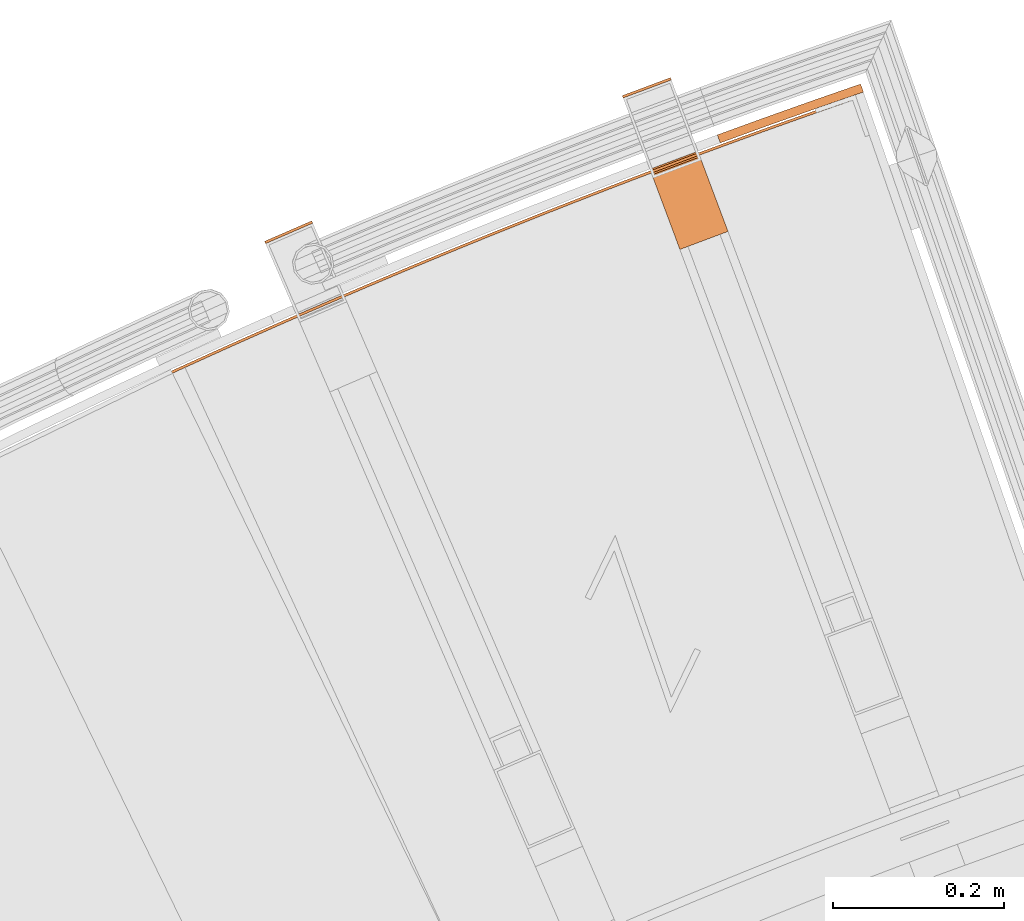
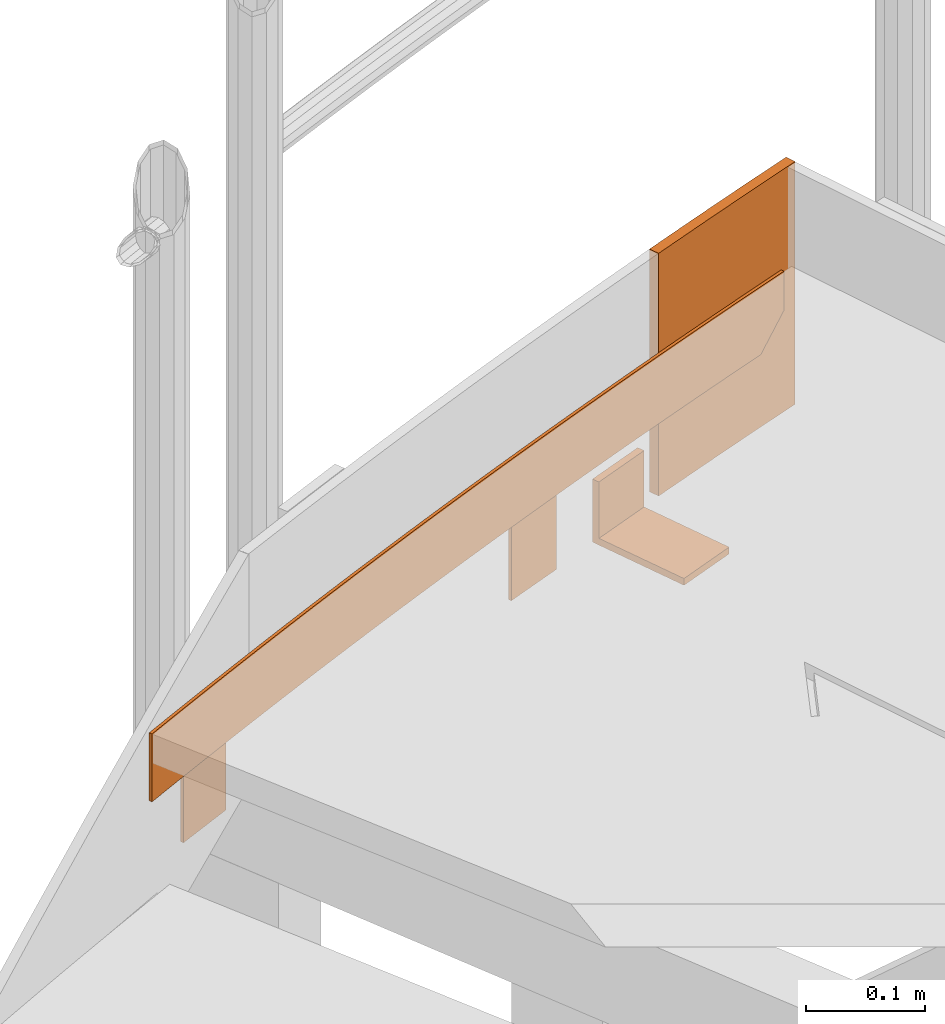
# One storey, part 98 of 126: 5 proxies.
"""IFC2X3 building model written with IfcOpenShell, lengths in millimetres."""

import ifcopenshell
import ifcopenshell.guid

model = None  # the IFC model being written
_history = None  # IfcOwnerHistory: only IFC2X3 demands one
_inside = {}  # id of a spatial element -> (the spatial element, [elements in it])
_under = {}  # id of a project, library or spatial element -> (it, [spatial elements below it])
_declared = {}  # id of a project -> (the project, [libraries it declares])
_typed = {}  # id of a type object -> (the type object, [elements of that type])
_made_of = {}  # id of a material, layer set ... -> (it, [elements and type objects made of it])


def new_model(schema):
    """Start an empty IFC model of exactly this schema.

    Asked for "IFC4X3", IfcOpenShell would pick the latest addendum, in which some entities
    have other attributes; the version numbers below select the first issue.
    IFC2X3 requires an IfcOwnerHistory on every rooted entity: one is made here for all.
    """
    global model, _history
    if schema == "IFC4X3":
        model = ifcopenshell.file(schema_version=(4, 3, 0, 0))
    else:
        model = ifcopenshell.file(schema=schema)
    _inside.clear()
    _under.clear()
    _declared.clear()
    _typed.clear()
    _made_of.clear()
    _history = None
    if model.schema == "IFC2X3":
        org = make("IfcOrganization", Name="unknown")
        user = make(
            "IfcPersonAndOrganization",
            ThePerson=make("IfcPerson", FamilyName="unknown"),
            TheOrganization=org,
        )
        app = make(
            "IfcApplication",
            ApplicationDeveloper=org,
            Version="unknown",
            ApplicationFullName="unknown",
            ApplicationIdentifier="unknown",
        )
        _history = make(
            "IfcOwnerHistory",
            OwningUser=user,
            OwningApplication=app,
            ChangeAction="ADDED",
            CreationDate=0,
        )
    return model


def make(cls, **values):
    """One entity of the class cls with the attributes given. An attribute that is None is left unset."""
    return model.create_entity(
        cls, **{name: value for name, value in values.items() if value is not None}
    )


def rooted(cls, **values):
    """An entity with a GlobalId (a new one), such as an element, a storey or a relation."""
    return make(cls, GlobalId=ifcopenshell.guid.new(), OwnerHistory=_history, **values)


def si_unit(unit_type, name, prefix=None):
    """IfcSIUnit, for example si_unit("LENGTHUNIT", "METRE", prefix="MILLI")."""
    return make("IfcSIUnit", UnitType=unit_type, Prefix=prefix, Name=name)


def assignment(units):
    """IfcUnitAssignment: the units of a project."""
    return None if units is None else make("IfcUnitAssignment", Units=units)


def point(xyz):
    """IfcCartesianPoint."""
    return None if xyz is None else make("IfcCartesianPoint", Coordinates=xyz)


def direction(xyz):
    """IfcDirection."""
    return None if xyz is None else make("IfcDirection", DirectionRatios=xyz)


def frame(location, z_axis=None, x_axis=None):
    """IfcAxis2Placement3D, a coordinate frame: its origin and axes. An axis left out is left unset."""
    return make(
        "IfcAxis2Placement3D",
        Location=point(location),
        Axis=direction(z_axis),
        RefDirection=direction(x_axis),
    )


def origin():
    """The frame at (0, 0, 0) with its axes left unset."""
    return frame((0.0, 0.0, 0.0))


def origin_with_axes():
    """The frame at (0, 0, 0) with the z axis (0, 0, 1) and the x axis (1, 0, 0) written out."""
    return frame((0.0, 0.0, 0.0), z_axis=(0.0, 0.0, 1.0), x_axis=(1.0, 0.0, 0.0))


def place(relative_to, where):
    """IfcLocalPlacement: puts the frame where relative to a parent placement (None: the world)."""
    return make(
        "IfcLocalPlacement", PlacementRelTo=relative_to, RelativePlacement=where
    )


def context(
    kind, dimensions, precision=None, world=None, true_north=None, identifier=None
):
    """IfcGeometricRepresentationContext, for example the 3D "Model" context."""
    return make(
        "IfcGeometricRepresentationContext",
        ContextIdentifier=identifier,
        ContextType=kind,
        CoordinateSpaceDimension=dimensions,
        Precision=precision,
        WorldCoordinateSystem=world,
        TrueNorth=true_north,
    )


def project(units=None, contexts=None):
    """IfcProject with its units and contexts."""
    return rooted(
        "IfcProject",
        Name="project",
        RepresentationContexts=contexts,
        UnitsInContext=assignment(units),
    )


def spatial(cls, under=None, at=None, **own):
    """A site, building, storey or space (cls), placed at a placement, below another one or the project."""
    s = rooted(cls, ObjectPlacement=at, **own)
    if under is not None:
        _under.setdefault(under.id(), (under, []))[1].append(s)
    return s


def faces_of(points, faces, orient=None, outer=None):
    """IfcFace entities. A face is a list of loops; a loop is a list of indices into points, from 0.

    orient and outer hold one flag for each loop. By default every Orientation is true, the
    first loop of a face is its IfcFaceOuterBound and the others are IfcFaceBound.
    """
    made = []
    for i, loops in enumerate(faces):
        bounds = []
        for j, loop in enumerate(loops):
            is_outer = j == 0 if outer is None else outer[i][j]
            bounds.append(
                make(
                    "IfcFaceOuterBound" if is_outer else "IfcFaceBound",
                    Bound=make("IfcPolyLoop", Polygon=[points[k] for k in loop]),
                    Orientation=True if orient is None else orient[i][j],
                )
            )
        made.append(make("IfcFace", Bounds=bounds))
    return made


def faceted_brep(points, faces, orient=None, outer=None, voids=None):
    """IfcFacetedBrep: a solid bounded by flat faces; with voids (closed shells), ...WithVoids."""
    shared = [point(p) for p in points]
    hull = make("IfcClosedShell", CfsFaces=faces_of(shared, faces, orient, outer))
    if voids is None:
        return make("IfcFacetedBrep", Outer=hull)
    return make(
        "IfcFacetedBrepWithVoids",
        Outer=hull,
        Voids=[
            make(cls, CfsFaces=faces_of(shared, fs, o, b)) for cls, fs, o, b in voids
        ],
    )


def shape(context_of_items, identifier, shape_type, items):
    """IfcShapeRepresentation: the items that make up one representation, for example the "Body"."""
    return make(
        "IfcShapeRepresentation",
        ContextOfItems=context_of_items,
        RepresentationIdentifier=identifier,
        RepresentationType=shape_type,
        Items=items,
    )


def material(Name=None, Category=None):
    """IfcMaterial."""
    return make("IfcMaterial", Name=Name, Category=Category)


def made_of(thing, what):
    """Note that an element or type object is made of a material, layer set ...; save() writes the relation."""
    if what is not None:
        _made_of.setdefault(what.id(), (what, []))[1].append(thing)
    return thing


def element(
    cls,
    number,
    at=None,
    inside=None,
    cuts=None,
    type_object=None,
    material=None,
    context=None,
    identifier="Body",
    shape_type=None,
    held_by="IfcProductDefinitionShape",
    body=None,
    shapes=None,
    **own,
):
    """One element of the class cls, such as IfcWall. Its Tag is "e" and its number.

    at: its placement. inside: the storey or other place that contains it. cuts: it is an
    opening in that element (IfcRelVoidsElement). A single representation is given by context,
    identifier, shape_type and body (its items); several are given by shapes. held_by: the class
    of the entity that holds the representations. save() writes the other relations.
    """
    e = rooted(cls, Tag="e%d" % number, ObjectPlacement=at, **own)
    if body is not None:
        shapes = [shape(context, identifier, shape_type, body)]
    if shapes is not None:
        e.Representation = make(held_by, Representations=shapes)
    if inside is not None:
        _inside.setdefault(inside.id(), (inside, []))[1].append(e)
    if cuts is not None:
        rooted(
            "IfcRelVoidsElement", RelatingBuildingElement=cuts, RelatedOpeningElement=e
        )
    if type_object is not None:
        _typed.setdefault(type_object.id(), (type_object, []))[1].append(e)
    return made_of(e, material)


def aggregate(whole, parts):
    """IfcRelAggregates: a whole, such as a stair, and the parts it consists of."""
    return rooted("IfcRelAggregates", RelatingObject=whole, RelatedObjects=parts)


def save(model, path):
    """Write the relations noted so far, then the file.

    IfcRelAggregates (storeys below a building ...), IfcRelContainedInSpatialStructure (elements
    in a storey), IfcRelDefinesByType, IfcRelAssociatesMaterial and IfcRelDeclares: one each for
    every whole, place, type object, material and project.
    """
    for whole, parts in _under.values():
        aggregate(whole, parts)
    for where, things in _inside.values():
        rooted(
            "IfcRelContainedInSpatialStructure",
            RelatedElements=things,
            RelatingStructure=where,
        )
    for kind, things in _typed.values():
        rooted("IfcRelDefinesByType", RelatedObjects=things, RelatingType=kind)
    for what, things in _made_of.values():
        rooted("IfcRelAssociatesMaterial", RelatedObjects=things, RelatingMaterial=what)
    for by, libraries in _declared.values():
        rooted("IfcRelDeclares", RelatingContext=by, RelatedDefinitions=libraries)
    model.write(path)


model = new_model("IFC2X3")

# Units and contexts
context_of_model_1 = context(None, 3, precision=0.1, world=origin())
context_of_model_2 = context(None, 3, precision=0.1, world=origin())
ifc_project = project(units=[si_unit("LENGTHUNIT", "METRE", prefix="MILLI"), si_unit("AREAUNIT", "SQUARE_METRE", prefix="CENTI"), si_unit("VOLUMEUNIT", "CUBIC_METRE", prefix="CENTI"), si_unit("MASSUNIT", "GRAM", prefix="KILO")], contexts=[context_of_model_1, context_of_model_2])

# Site, building, storey
site_placement = place(None, origin_with_axes())
site = spatial("IfcSite", under=ifc_project, at=site_placement, CompositionType="ELEMENT")
building_placement = place(site_placement, origin_with_axes())
building = spatial("IfcBuilding", under=site, at=building_placement, CompositionType="ELEMENT")
storey_placement = place(building_placement, origin_with_axes())
storey = spatial("IfcBuildingStorey", under=building, at=storey_placement, CompositionType="ELEMENT")

# Proxies
ifc_material = material(Name="S235JRG2")
proxy_1_placement = place(storey_placement, origin_with_axes())
element("IfcBuildingElementProxy", 1, at=proxy_1_placement, inside=storey, material=ifc_material, context=context_of_model_2, shape_type="Brep", body=[
    faceted_brep([(4491.5336, 16193.806, 10835.15), (4492.7258, 16191.053, 10835.15), (4437.6668, 16167.21, 10835.15), (4436.4746, 16169.963, 10835.15), (4491.5336, 16193.806, 10935.15), (4436.4746, 16169.963, 10935.15), (4437.6668, 16167.21, 10935.15), (4492.7258, 16191.053, 10935.15)], [[[0, 1, 2, 3]], [[4, 5, 6, 7]], [[0, 4, 7, 1]], [[1, 7, 6, 2]], [[2, 6, 5, 3]], [[3, 5, 4, 0]]]),
])
proxy_2_placement = place(storey_placement, origin_with_axes())
element("IfcBuildingElementProxy", 2, at=proxy_2_placement, inside=storey, material=ifc_material, context=context_of_model_2, shape_type="Brep", body=[
    faceted_brep([(4910.3289, 16361.076, 10835.15), (4911.3803, 16358.266, 10835.15), (4855.1855, 16337.239, 10835.15), (4854.1341, 16340.049, 10835.15), (4910.3289, 16361.076, 10935.15), (4854.1341, 16340.049, 10935.15), (4855.1855, 16337.239, 10935.15), (4911.3803, 16358.266, 10935.15)], [[[0, 1, 2, 3]], [[4, 5, 6, 7]], [[0, 4, 7, 1]], [[1, 7, 6, 2]], [[2, 6, 5, 3]], [[3, 5, 4, 0]]]),
])
proxy_3_placement = place(storey_placement, origin_with_axes())
element("IfcBuildingElementProxy", 3, at=proxy_3_placement, inside=storey, material=ifc_material, context=context_of_model_2, shape_type="Brep", body=[
    faceted_brep([(4886.3098, 16254.06, 11000.15), (4942.5046, 16275.087, 11000.15), (4942.5046, 16275.087, 10935.15), (4886.3098, 16254.06, 10935.15), (4888.763, 16247.504, 11000.15), (4944.9578, 16268.531, 11000.15), (4888.763, 16247.504, 10942.15), (4944.9578, 16268.531, 10942.15), (4921.355, 16160.402, 10942.15), (4977.5499, 16181.429, 10942.15), (4921.355, 16160.402, 10935.15), (4977.5499, 16181.429, 10935.15)], [[[0, 1, 2, 3]], [[0, 4, 5, 1]], [[4, 6, 7, 5]], [[6, 8, 9, 7]], [[8, 10, 11, 9]], [[3, 2, 11, 10]], [[3, 10, 8, 6, 4, 0]], [[1, 5, 7, 9, 11, 2]]]),
])
proxy_4_placement = place(storey_placement, origin_with_axes())
element("IfcBuildingElementProxy", 4, at=proxy_4_placement, inside=storey, material=ifc_material, context=context_of_model_2, shape_type="Brep", body=[
    faceted_brep([(4315.0715, 16012.741, 11015.15), (4316.327, 16010.016, 11015.15), (4316.327, 16010.016, 11085.15), (4315.0715, 16012.741, 11085.15), (4322.9299, 16016.362, 11015.15), (4324.1827, 16013.636, 11015.15), (4324.1827, 16013.636, 11085.15), (4322.9299, 16016.362, 11085.15), (4338.6607, 16023.573, 11015.15), (4339.9082, 16020.845, 11015.15), (4339.9082, 16020.845, 11085.15), (4338.6607, 16023.573, 11085.15), (4354.4057, 16030.754, 11015.15), (4355.6478, 16028.023, 11015.15), (4355.6478, 16028.023, 11085.15), (4354.4057, 16030.754, 11085.15), (4370.1648, 16037.903, 11015.15), (4371.4015, 16035.17, 11015.15), (4371.4015, 16035.17, 11085.15), (4370.1648, 16037.903, 11085.15), (4385.9378, 16045.022, 11015.15), (4387.1692, 16042.286, 11015.15), (4387.1692, 16042.286, 11085.15), (4385.9378, 16045.022, 11085.15), (4401.7248, 16052.109, 11015.15), (4402.9508, 16049.371, 11015.15), (4402.9508, 16049.371, 11085.15), (4401.7248, 16052.109, 11085.15), (4417.5257, 16059.166, 11015.15), (4418.7463, 16056.425, 11015.15), (4418.7463, 16056.425, 11085.15), (4417.5257, 16059.166, 11085.15), (4433.3404, 16066.192, 11015.15), (4434.5556, 16063.449, 11015.15), (4434.5556, 16063.449, 11085.15), (4433.3404, 16066.192, 11085.15), (4449.1688, 16073.186, 11015.15), (4450.3787, 16070.441, 11015.15), (4450.3787, 16070.441, 11085.15), (4449.1688, 16073.186, 11085.15), (4465.011, 16080.149, 11015.15), (4466.2154, 16077.402, 11015.15), (4466.2154, 16077.402, 11085.15), (4465.011, 16080.149, 11085.15), (4480.8667, 16087.082, 11015.15), (4482.0658, 16084.332, 11015.15), (4482.0658, 16084.332, 11085.15), (4480.8667, 16087.082, 11085.15), (4496.7361, 16093.983, 11015.15), (4497.9298, 16091.231, 11015.15), (4497.9298, 16091.231, 11085.15), (4496.7361, 16093.983, 11085.15), (4512.619, 16100.853, 11015.15), (4513.8072, 16098.098, 11015.15), (4513.8072, 16098.098, 11085.15), (4512.619, 16100.853, 11085.15), (4528.5153, 16107.692, 11015.15), (4529.6982, 16104.935, 11015.15), (4529.6982, 16104.935, 11085.15), (4528.5153, 16107.692, 11085.15), (4544.425, 16114.499, 11015.15), (4545.6025, 16111.74, 11015.15), (4545.6025, 16111.74, 11085.15), (4544.425, 16114.499, 11085.15), (4560.3481, 16121.276, 11015.15), (4561.5201, 16118.514, 11015.15), (4561.5201, 16118.514, 11085.15), (4560.3481, 16121.276, 11085.15), (4576.2844, 16128.021, 11015.15), (4577.451, 16125.257, 11015.15), (4577.451, 16125.257, 11085.15), (4576.2844, 16128.021, 11085.15), (4592.2339, 16134.735, 11015.15), (4593.3951, 16131.968, 11015.15), (4593.3951, 16131.968, 11085.15), (4592.2339, 16134.735, 11085.15), (4608.1966, 16141.417, 11015.15), (4609.3523, 16138.649, 11015.15), (4609.3523, 16138.649, 11085.15), (4608.1966, 16141.417, 11085.15), (4624.1723, 16148.068, 11015.15), (4625.3226, 16145.298, 11015.15), (4625.3226, 16145.298, 11085.15), (4624.1723, 16148.068, 11085.15), (4640.1611, 16154.688, 11015.15), (4641.306, 16151.915, 11015.15), (4641.306, 16151.915, 11085.15), (4640.1611, 16154.688, 11085.15), (4656.1628, 16161.276, 11015.15), (4657.3023, 16158.501, 11015.15), (4657.3023, 16158.501, 11085.15), (4656.1628, 16161.276, 11085.15), (4672.1775, 16167.833, 11015.15), (4673.3115, 16165.056, 11015.15), (4673.3115, 16165.056, 11085.15), (4672.1775, 16167.833, 11085.15), (4688.205, 16174.359, 11015.15), (4689.3335, 16171.579, 11015.15), (4689.3335, 16171.579, 11085.15), (4688.205, 16174.359, 11085.15), (4704.2452, 16180.853, 11015.15), (4705.3683, 16178.071, 11015.15), (4705.3683, 16178.071, 11085.15), (4704.2452, 16180.853, 11085.15), (4720.2982, 16187.316, 11015.15), (4721.4158, 16184.531, 11015.15), (4721.4158, 16184.531, 11085.15), (4720.2982, 16187.316, 11085.15), (4736.3638, 16193.747, 11015.15), (4737.476, 16190.96, 11015.15), (4737.476, 16190.96, 11085.15), (4736.3638, 16193.747, 11085.15), (4752.442, 16200.146, 11015.15), (4753.5487, 16197.358, 11015.15), (4753.5487, 16197.358, 11085.15), (4752.442, 16200.146, 11085.15), (4768.5328, 16206.514, 11015.15), (4769.634, 16203.724, 11015.15), (4769.634, 16203.724, 11085.15), (4768.5328, 16206.514, 11085.15), (4784.636, 16212.85, 11015.15), (4785.7317, 16210.058, 11015.15), (4785.7317, 16210.058, 11085.15), (4784.636, 16212.85, 11085.15), (4800.7516, 16219.155, 11015.15), (4801.8418, 16216.36, 11015.15), (4801.8418, 16216.36, 11085.15), (4800.7516, 16219.155, 11085.15), (4816.8795, 16225.428, 11015.15), (4817.9643, 16222.631, 11015.15), (4817.9643, 16222.631, 11085.15), (4816.8795, 16225.428, 11085.15), (4833.0198, 16231.67, 11015.15), (4834.0991, 16228.871, 11015.15), (4834.0991, 16228.871, 11085.15), (4833.0198, 16231.67, 11085.15), (4849.1722, 16237.879, 11015.15), (4850.246, 16235.078, 11015.15), (4850.246, 16235.078, 11085.15), (4849.1722, 16237.879, 11085.15), (4865.3369, 16244.057, 11015.15), (4866.4051, 16241.254, 11015.15), (4866.4051, 16241.254, 11085.15), (4865.3369, 16244.057, 11085.15), (4881.5136, 16250.204, 11015.15), (4882.5763, 16247.398, 11015.15), (4882.5763, 16247.398, 11085.15), (4881.5136, 16250.204, 11085.15), (4897.7023, 16256.318, 11015.15), (4898.7596, 16253.511, 11015.15), (4898.7596, 16253.511, 11085.15), (4897.7023, 16256.318, 11085.15), (4913.903, 16262.401, 11015.15), (4914.9548, 16259.591, 11015.15), (4914.9548, 16259.591, 11085.15), (4913.903, 16262.401, 11085.15), (4930.1156, 16268.452, 11015.15), (4931.1619, 16265.64, 11015.15), (4931.1619, 16265.64, 11085.15), (4930.1156, 16268.452, 11085.15), (4946.3401, 16274.471, 11015.15), (4947.3808, 16271.657, 11015.15), (4947.3808, 16271.657, 11085.15), (4946.3401, 16274.471, 11085.15), (4962.5764, 16280.458, 11015.15), (4963.6115, 16277.642, 11015.15), (4963.6115, 16277.642, 11085.15), (4962.5764, 16280.458, 11085.15), (4978.8243, 16286.414, 11015.15), (4979.854, 16283.596, 11015.15), (4979.854, 16283.596, 11085.15), (4978.8243, 16286.414, 11085.15), (4995.0839, 16292.337, 11015.15), (4996.1081, 16289.517, 11015.15), (4996.1081, 16289.517, 11085.15), (4995.0839, 16292.337, 11085.15), (5011.3552, 16298.228, 11015.15), (5012.3738, 16295.407, 11015.15), (5012.3738, 16295.407, 11085.15), (5011.3552, 16298.228, 11085.15), (5027.6379, 16304.088, 11015.15), (5028.651, 16301.264, 11015.15), (5028.651, 16301.264, 11085.15), (5027.6379, 16304.088, 11085.15), (5043.9321, 16309.916, 11015.15), (5044.9396, 16307.09, 11015.15), (5044.9396, 16307.09, 11085.15), (5043.9321, 16309.916, 11085.15), (5060.2378, 16315.711, 11015.15), (5061.2397, 16312.884, 11015.15), (5061.2397, 16312.884, 11085.15), (5060.2378, 16315.711, 11085.15), (5076.5547, 16321.475, 11015.15), (5077.5511, 16318.645, 11015.15), (5077.5511, 16318.645, 11085.15), (5076.5547, 16321.475, 11085.15), (5088.9364, 16325.821, 11015.15), (5090.1975, 16323.084, 11015.15), (5093.8738, 16324.375, 11019.029), (5093.8738, 16324.375, 11085.15), (5092.883, 16327.207, 11085.15), (5092.883, 16327.207, 11019.314), (5110.2077, 16330.072, 11036.248), (5110.2077, 16330.072, 11085.15), (5109.2224, 16332.906, 11085.15), (5109.2224, 16332.906, 11036.539), (5118.3803, 16332.905, 11044.856), (5118.3803, 16332.905, 11085.15), (5117.3978, 16335.74, 11085.15), (5117.3978, 16335.74, 11045.15)], [[[0, 1, 2, 3]], [[0, 4, 5, 1]], [[1, 5, 6, 2]], [[2, 6, 7, 3]], [[3, 7, 4, 0]], [[4, 8, 9, 5]], [[5, 9, 10, 6]], [[6, 10, 11, 7]], [[7, 11, 8, 4]], [[8, 12, 13, 9]], [[9, 13, 14, 10]], [[10, 14, 15, 11]], [[11, 15, 12, 8]], [[12, 16, 17, 13]], [[13, 17, 18, 14]], [[14, 18, 19, 15]], [[15, 19, 16, 12]], [[16, 20, 21, 17]], [[17, 21, 22, 18]], [[18, 22, 23, 19]], [[19, 23, 20, 16]], [[20, 24, 25, 21]], [[21, 25, 26, 22]], [[22, 26, 27, 23]], [[23, 27, 24, 20]], [[24, 28, 29, 25]], [[25, 29, 30, 26]], [[26, 30, 31, 27]], [[27, 31, 28, 24]], [[28, 32, 33, 29]], [[29, 33, 34, 30]], [[30, 34, 35, 31]], [[31, 35, 32, 28]], [[32, 36, 37, 33]], [[33, 37, 38, 34]], [[34, 38, 39, 35]], [[35, 39, 36, 32]], [[36, 40, 41, 37]], [[37, 41, 42, 38]], [[38, 42, 43, 39]], [[39, 43, 40, 36]], [[40, 44, 45, 41]], [[41, 45, 46, 42]], [[42, 46, 47, 43]], [[43, 47, 44, 40]], [[44, 48, 49, 45]], [[45, 49, 50, 46]], [[46, 50, 51, 47]], [[47, 51, 48, 44]], [[48, 52, 53, 49]], [[49, 53, 54, 50]], [[50, 54, 55, 51]], [[51, 55, 52, 48]], [[52, 56, 57, 53]], [[53, 57, 58, 54]], [[54, 58, 59, 55]], [[55, 59, 56, 52]], [[56, 60, 61, 57]], [[57, 61, 62, 58]], [[58, 62, 63, 59]], [[59, 63, 60, 56]], [[60, 64, 65, 61]], [[61, 65, 66, 62]], [[62, 66, 67, 63]], [[63, 67, 64, 60]], [[64, 68, 69, 65]], [[65, 69, 70, 66]], [[66, 70, 71, 67]], [[67, 71, 68, 64]], [[68, 72, 73, 69]], [[69, 73, 74, 70]], [[70, 74, 75, 71]], [[71, 75, 72, 68]], [[72, 76, 77, 73]], [[73, 77, 78, 74]], [[74, 78, 79, 75]], [[75, 79, 76, 72]], [[76, 80, 81, 77]], [[77, 81, 82, 78]], [[78, 82, 83, 79]], [[79, 83, 80, 76]], [[80, 84, 85, 81]], [[81, 85, 86, 82]], [[82, 86, 87, 83]], [[83, 87, 84, 80]], [[84, 88, 89, 85]], [[85, 89, 90, 86]], [[86, 90, 91, 87]], [[87, 91, 88, 84]], [[88, 92, 93, 89]], [[89, 93, 94, 90]], [[90, 94, 95, 91]], [[91, 95, 92, 88]], [[92, 96, 97, 93]], [[93, 97, 98, 94]], [[94, 98, 99, 95]], [[95, 99, 96, 92]], [[96, 100, 101, 97]], [[97, 101, 102, 98]], [[98, 102, 103, 99]], [[99, 103, 100, 96]], [[100, 104, 105, 101]], [[101, 105, 106, 102]], [[102, 106, 107, 103]], [[103, 107, 104, 100]], [[104, 108, 109, 105]], [[105, 109, 110, 106]], [[106, 110, 111, 107]], [[107, 111, 108, 104]], [[108, 112, 113, 109]], [[109, 113, 114, 110]], [[110, 114, 115, 111]], [[111, 115, 112, 108]], [[112, 116, 117, 113]], [[113, 117, 118, 114]], [[114, 118, 119, 115]], [[115, 119, 116, 112]], [[116, 120, 121, 117]], [[117, 121, 122, 118]], [[118, 122, 123, 119]], [[119, 123, 120, 116]], [[120, 124, 125, 121]], [[121, 125, 126, 122]], [[122, 126, 127, 123]], [[123, 127, 124, 120]], [[124, 128, 129, 125]], [[125, 129, 130, 126]], [[126, 130, 131, 127]], [[127, 131, 128, 124]], [[128, 132, 133, 129]], [[129, 133, 134, 130]], [[130, 134, 135, 131]], [[131, 135, 132, 128]], [[132, 136, 137, 133]], [[133, 137, 138, 134]], [[134, 138, 139, 135]], [[135, 139, 136, 132]], [[136, 140, 141, 137]], [[137, 141, 142, 138]], [[138, 142, 143, 139]], [[139, 143, 140, 136]], [[140, 144, 145, 141]], [[141, 145, 146, 142]], [[142, 146, 147, 143]], [[143, 147, 144, 140]], [[144, 148, 149, 145]], [[145, 149, 150, 146]], [[146, 150, 151, 147]], [[147, 151, 148, 144]], [[148, 152, 153, 149]], [[149, 153, 154, 150]], [[150, 154, 155, 151]], [[151, 155, 152, 148]], [[152, 156, 157, 153]], [[153, 157, 158, 154]], [[154, 158, 159, 155]], [[155, 159, 156, 152]], [[156, 160, 161, 157]], [[157, 161, 162, 158]], [[158, 162, 163, 159]], [[159, 163, 160, 156]], [[160, 164, 165, 161]], [[161, 165, 166, 162]], [[162, 166, 167, 163]], [[163, 167, 164, 160]], [[164, 168, 169, 165]], [[165, 169, 170, 166]], [[166, 170, 171, 167]], [[167, 171, 168, 164]], [[168, 172, 173, 169]], [[169, 173, 174, 170]], [[170, 174, 175, 171]], [[171, 175, 172, 168]], [[172, 176, 177, 173]], [[173, 177, 178, 174]], [[174, 178, 179, 175]], [[175, 179, 176, 172]], [[176, 180, 181, 177]], [[177, 181, 182, 178]], [[178, 182, 183, 179]], [[179, 183, 180, 176]], [[180, 184, 185, 181]], [[181, 185, 186, 182]], [[182, 186, 187, 183]], [[183, 187, 184, 180]], [[184, 188, 189, 185]], [[185, 189, 190, 186]], [[186, 190, 191, 187]], [[187, 191, 188, 184]], [[188, 192, 193, 189]], [[189, 193, 194, 190]], [[190, 194, 195, 191]], [[191, 195, 192, 188]], [[192, 196, 197, 193]], [[193, 197, 198, 199, 194]], [[194, 199, 200, 195]], [[192, 195, 200, 201, 196]], [[198, 202, 203, 199]], [[199, 203, 204, 200]], [[200, 204, 205, 201]], [[203, 202, 206, 207]], [[203, 207, 208, 204]], [[204, 208, 209, 205]], [[207, 206, 209, 208]], [[196, 201, 205, 209, 206, 202, 198, 197]]]),
])
proxy_5_placement = place(storey_placement, origin_with_axes())
element("IfcBuildingElementProxy", 5, at=proxy_5_placement, inside=storey, material=ifc_material, context=context_of_model_2, shape_type="Brep", body=[
    faceted_brep([(4965.0224, 16294.193, 10935.15), (5022.9655, 16315.214, 10935.15), (5026.343, 16305.802, 10935.15), (4968.4656, 16284.805, 10935.15), (5026.343, 16305.802, 11185.15), (4968.4656, 16284.805, 11185.15), (5022.9655, 16315.214, 11185.15), (4965.0224, 16294.193, 11185.15), (5081.0539, 16335.83, 10935.15), (5084.3657, 16326.394, 10935.15), (5084.3657, 16326.394, 11185.15), (5081.0539, 16335.83, 11185.15), (5132.361, 16353.637, 10935.15), (5135.6368, 16344.189, 10935.15), (5135.6368, 16344.189, 11185.15), (5132.361, 16353.637, 11185.15)], [[[0, 1, 2, 3]], [[3, 2, 4, 5]], [[5, 4, 6, 7]], [[7, 6, 1, 0]], [[1, 8, 9, 2]], [[2, 9, 10, 4]], [[4, 10, 11, 6]], [[6, 11, 8, 1]], [[8, 12, 13, 9]], [[9, 13, 14, 10]], [[10, 14, 15, 11]], [[8, 11, 15, 12]], [[0, 3, 5, 7]], [[12, 15, 14, 13]]]),
])

save(model, "model.ifc")
